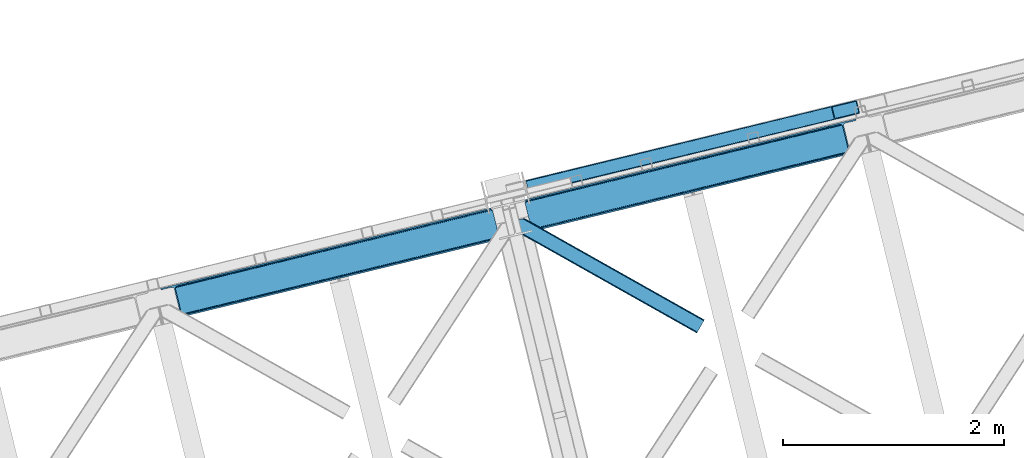
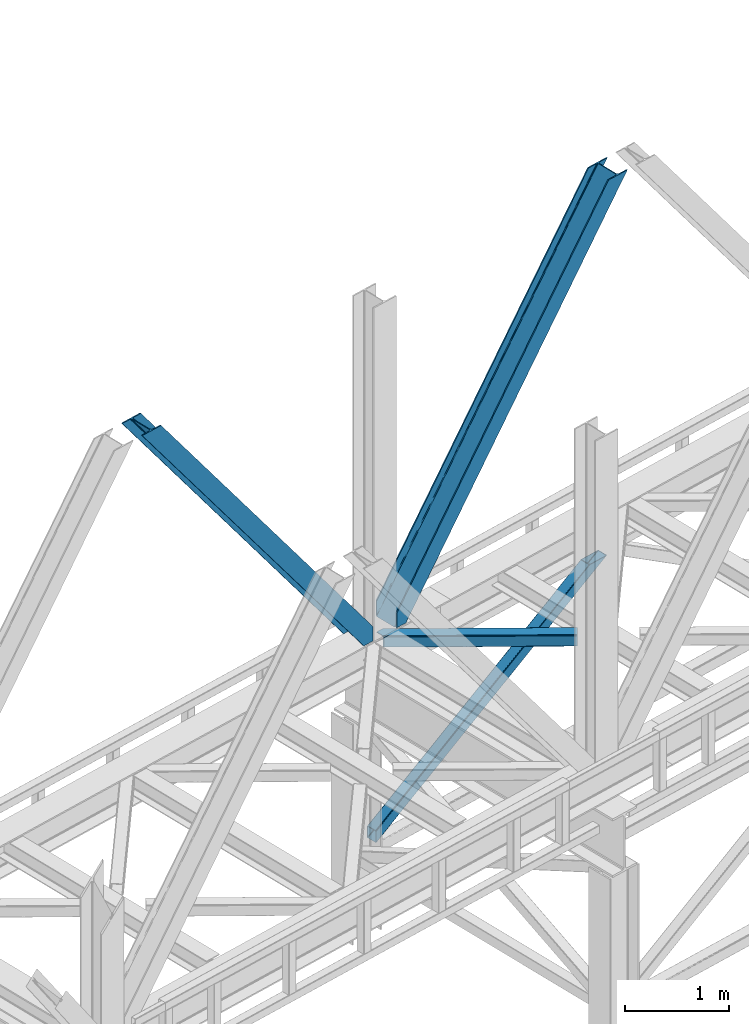
# One storey, part 45 of 93: 4 members.
"""IFC4 building model written with IfcOpenShell, lengths in millimetres."""

from ifc_helpers import new_model, entity, si_unit, converted_unit, derived_unit, direction, frame, origin, place, context, subcontext, project, spatial, triangles, type_object, element, save


model = new_model("IFC4")

# Units and contexts
model_context = context("Model", 3, precision=0.01, world=origin(), true_north=direction((6.12303176911189e-17, 1.0)))
plan_context = context("Plan", 3, precision=0.01, world=origin(), true_north=direction((6.12303176911189e-17, 1.0)))
body_context = subcontext(model_context, "Body", "Model", "MODEL_VIEW")
ifc_project = project(units=[si_unit("LENGTHUNIT", "METRE", prefix="MILLI"), si_unit("AREAUNIT", "SQUARE_METRE"), si_unit("VOLUMEUNIT", "CUBIC_METRE"), converted_unit("PLANEANGLEUNIT", "DEGREE", entity("IfcRatioMeasure", 0.0174532925199433), si_unit("PLANEANGLEUNIT", "RADIAN"), dimensions=[0, 0, 0, 0, 0, 0, 0]), si_unit("MASSUNIT", "GRAM", prefix="KILO"), derived_unit("MASSDENSITYUNIT", [(si_unit("MASSUNIT", "GRAM", prefix="KILO"), 1), (si_unit("LENGTHUNIT", "METRE"), -3)]), derived_unit("MOMENTOFINERTIAUNIT", [(si_unit("LENGTHUNIT", "METRE"), 4)]), si_unit("TIMEUNIT", "SECOND"), si_unit("FREQUENCYUNIT", "HERTZ"), si_unit("THERMODYNAMICTEMPERATUREUNIT", "DEGREE_CELSIUS"), derived_unit("THERMALTRANSMITTANCEUNIT", [(si_unit("MASSUNIT", "GRAM", prefix="KILO"), 1), (si_unit("THERMODYNAMICTEMPERATUREUNIT", "KELVIN"), -1), (si_unit("TIMEUNIT", "SECOND"), -3)]), derived_unit("VOLUMETRICFLOWRATEUNIT", [(si_unit("LENGTHUNIT", "METRE"), 3), (si_unit("TIMEUNIT", "SECOND"), -1)]), derived_unit("MASSFLOWRATEUNIT", [(si_unit("MASSUNIT", "GRAM", prefix="KILO"), 1), (si_unit("TIMEUNIT", "SECOND"), -1)]), derived_unit("ROTATIONALFREQUENCYUNIT", [(si_unit("TIMEUNIT", "SECOND"), -1)]), si_unit("ELECTRICCURRENTUNIT", "AMPERE"), si_unit("ELECTRICVOLTAGEUNIT", "VOLT"), si_unit("POWERUNIT", "WATT"), si_unit("FORCEUNIT", "NEWTON", prefix="KILO"), si_unit("ILLUMINANCEUNIT", "LUX"), si_unit("LUMINOUSFLUXUNIT", "LUMEN"), si_unit("LUMINOUSINTENSITYUNIT", "CANDELA"), derived_unit("USERDEFINED", [(si_unit("MASSUNIT", "GRAM", prefix="KILO"), -1), (si_unit("LENGTHUNIT", "METRE"), -2), (si_unit("TIMEUNIT", "SECOND"), 3), (si_unit("LUMINOUSFLUXUNIT", "LUMEN"), 1)]), derived_unit("LINEARVELOCITYUNIT", [(si_unit("LENGTHUNIT", "METRE"), 1), (si_unit("TIMEUNIT", "SECOND"), -1)]), si_unit("PRESSUREUNIT", "PASCAL"), derived_unit("USERDEFINED", [(si_unit("LENGTHUNIT", "METRE"), -2), (si_unit("MASSUNIT", "GRAM", prefix="KILO"), 1), (si_unit("TIMEUNIT", "SECOND"), -2)]), derived_unit("LINEARFORCEUNIT", [(si_unit("MASSUNIT", "GRAM", prefix="KILO"), 1), (si_unit("LENGTHUNIT", "METRE"), 1), (si_unit("TIMEUNIT", "SECOND"), -2), (si_unit("LENGTHUNIT", "METRE"), -1)]), derived_unit("PLANARFORCEUNIT", [(si_unit("MASSUNIT", "GRAM", prefix="KILO"), 1), (si_unit("LENGTHUNIT", "METRE"), 1), (si_unit("TIMEUNIT", "SECOND"), -2), (si_unit("LENGTHUNIT", "METRE"), -2)])], contexts=[model_context, plan_context])

# Site, building, storey
site_placement = place(None, origin())
site = spatial("IfcSite", under=ifc_project, at=site_placement, CompositionType="ELEMENT")
building_placement = place(site_placement, origin())
building = spatial("IfcBuilding", under=site, at=building_placement, CompositionType="ELEMENT")
storey_placement = place(building_placement, frame((0.0, 0.0, 15900.0)))
storey = spatial("IfcBuildingStorey", under=building, at=storey_placement, CompositionType="ELEMENT", Elevation=15900.0)

# Members
member_type_1 = type_object("IfcMemberType", PredefinedType="BRACE")
member_1_placement = place(storey_placement, frame((-46122.2870727539, 9414.76370544434, 3694.99929199219)))
element("IfcMember", 1, at=member_1_placement, inside=storey, type_object=member_type_1, ObjectType="Steel Vertical Brace", PredefinedType="BRACE", context=body_context, shape_type="Tessellation", body=[
    triangles([(3067.37091064453, 755.49225769043, 0.827856445310317), (3068.02668457031, 754.50743408203, 1.13248901367115), (3066.59886474609, 754.045834350585, 0.0), (3064.67805175781, 761.925585937499, 0.0), (3064.21761474609, 752.73196105957, 7.29955444335792), (3064.21761474609, 752.73196105957, 0.0), (3059.99926757813, 741.228012084961, 0.0), (3059.6876586914, 743.591821289063, 30.563250732419), (3059.80393066406, 742.210510253906, 42.2602111816377), (3059.81788330078, 745.527749633789, 0.0), (3059.81788330078, 745.527749633789, 24.1799194335908), (3059.80393066406, 742.210510253906, 171.115136718749), (3059.99926757813, 741.228012084961, 171.175598144531), (3061.29686279297, 749.56936340332, 14.6921264648408), (3061.29686279297, 749.56936340332, 0.0), (3060.72015380859, 747.995040893555, 18.3872497558586), (215.726367187497, 48.9359664916992, 3911.00081176758), (310.450817871089, 72.0264175415032, 3911.00081176758), (192.834741210936, 54.7931671142578, 3911.00081176758), (198.969250488277, 50.2783264160153, 3911.00081176758), (207.010620117188, 48.2214752197269, 3911.00081176758), (189.532617187499, 61.0782485961918, 3911.00081176758), (3062.84095458984, 729.569421386719, 171.175598144531), (313.529699707025, 59.396374511718, 3911.00081176758), (3062.84095458984, 729.569421386719, 0.0), (2945.0109375, 700.846755981445, 0.0), (69.865502929686, 0.0, 3911.00081176758), (2941.93205566406, 713.477380371094, 0.0), (66.78662109375, 12.6300430297852, 3911.00081176758), (161.511071777342, 35.7204940795891, 3911.00081176758), (3036.65650634765, 736.567831420898, 0.0), (3054.3251953125, 759.401321411133, 0.0), (3054.28333740234, 752.301754760741, 0.0), (179.179760742183, 58.5539840698239, 3911.00081176758), (179.13790283203, 51.4544174194325, 3911.00081176758), (3050.91610107422, 745.469613647461, 0.0), (175.7706665039, 44.622857666016, 3911.00081176758), (3044.72578125, 739.944369506835, 0.0), (169.580346679686, 39.0970321655277, 3911.00081176758), (2999.14251708984, 985.772387695311, 0.0), (123.997082519527, 284.925631713866, 3911.00081176758), (2972.94876708984, 997.914669799804, 0.0), (2981.66916503906, 998.62974243164, 0.0), (106.523730468747, 297.782405090331, 3911.00081176758), (97.8033325195283, 297.067913818359, 3911.00081176758), (2989.70588378906, 996.572891235352, 0.0), (114.560449218749, 295.725553894043, 3911.00081176758), (2995.84039306641, 992.058050537109, 0.0), (120.694958496089, 291.211294555664, 3911.00081176758), (3.07888183593604, 273.977462768555, 3911.00081176758), (2878.22431640625, 974.82421875, 0.0), (2875.14543457031, 987.454843139649, 0.0), (0.0, 286.60750579834, 3911.00081176758), (3009.50002441406, 988.296652221679, 0.0), (134.354589843744, 287.449896240234, 3911.00081176758), (143.954003906249, 306.906266784668, 3911.00081176758), (243.668847656249, 346.004461669922, 3911.00081176758), (152.018627929683, 310.283386230469, 3911.00081176758), (137.763684082027, 301.381604003906, 3911.00081176758), (134.391796874996, 294.549462890625, 3911.00081176758), (246.747729492185, 333.373837280273, 3911.00081176758), (2992.97545166015, 1016.17750854492, 171.175598144531), (2992.97545166015, 1016.17750854492, 0.0), (2995.81713867188, 1004.51891784668, 171.175598144531), (2996.10084228515, 1003.55734863281, 171.115136718749), (2996.10084228515, 1003.55734863281, 42.2602111816377), (2995.81713867188, 1004.51891784668, 0.0), (3004.85844726562, 996.247329711914, 0.0), (2997.63563232421, 1000.61683044434, 0.0), (3000.81218261718, 997.712356567383, 0.0), (3007.57921142578, 996.176403808593, 0.0), (2996.63104248047, 1002.27719421387, 30.563250732419), (2997.79841308593, 1000.74124145508, 25.1542785644524), (2999.21228027344, 998.890191650391, 18.6337463378877), (3000.81218261718, 997.712356567383, 14.6921264648408), (3004.85844726562, 996.247329711914, 7.29955444335792), (3009.05819091797, 996.424063110351, 1.13248901367115), (3008.92796630859, 995.248553466796, 0.827856445310317)], [[1, 2, 3], [3, 4, 1], [5, 6, 3], [7, 8, 9], [7, 10, 11], [11, 8, 7], [9, 12, 13], [13, 7, 9], [14, 10, 15], [10, 14, 16], [11, 10, 16], [6, 5, 15], [14, 15, 5], [3, 2, 5], [17, 18, 12], [12, 9, 17], [1, 19, 5], [19, 20, 16], [16, 14, 19], [14, 5, 19], [20, 21, 8], [8, 11, 20], [9, 8, 21], [21, 17, 9], [11, 16, 20], [5, 2, 1], [1, 4, 19], [22, 19, 4], [13, 12, 18], [23, 13, 24], [18, 24, 13], [23, 25, 7], [7, 13, 23], [24, 26, 23], [24, 27, 26], [26, 25, 23], [28, 26, 29], [27, 29, 26], [29, 30, 28], [31, 28, 30], [32, 33, 34], [35, 34, 33], [33, 36, 35], [37, 35, 36], [36, 38, 37], [39, 37, 38], [38, 31, 39], [30, 39, 31], [40, 32, 41], [34, 41, 32], [42, 43, 44], [44, 45, 42], [43, 46, 47], [47, 44, 43], [46, 48, 49], [49, 47, 46], [48, 40, 41], [41, 49, 48], [45, 50, 51], [51, 42, 45], [52, 51, 50], [50, 53, 52], [4, 54, 55], [55, 22, 4], [41, 34, 55], [37, 39, 21], [30, 27, 24], [29, 27, 30], [39, 30, 17], [34, 35, 19], [35, 37, 20], [47, 56, 44], [53, 45, 57], [45, 44, 58], [53, 50, 45], [47, 49, 59], [49, 41, 60], [55, 34, 22], [17, 21, 39], [19, 35, 20], [21, 20, 37], [19, 22, 34], [24, 17, 30], [24, 18, 17], [58, 44, 56], [59, 49, 60], [55, 60, 41], [59, 56, 47], [58, 57, 45], [57, 58, 61], [57, 52, 53], [52, 57, 62], [63, 52, 62], [64, 62, 57], [65, 64, 61], [57, 61, 64], [61, 58, 65], [66, 65, 58], [64, 67, 62], [63, 62, 67], [32, 40, 54], [46, 43, 67], [42, 52, 63], [51, 52, 42], [43, 42, 63], [40, 48, 68], [48, 46, 69], [36, 7, 38], [26, 31, 25], [31, 38, 25], [26, 28, 31], [36, 33, 10], [33, 32, 6], [10, 7, 36], [54, 40, 68], [67, 69, 46], [63, 67, 43], [48, 69, 70], [70, 68, 48], [71, 54, 68], [32, 54, 4], [10, 33, 15], [33, 6, 15], [7, 25, 38], [32, 4, 6], [3, 6, 4], [67, 72, 73], [65, 66, 64], [67, 64, 66], [66, 72, 67], [69, 74, 75], [69, 73, 74], [76, 77, 71], [71, 68, 76], [76, 68, 70], [70, 75, 76], [75, 70, 69], [73, 69, 67], [60, 78, 76], [76, 59, 60], [76, 75, 59], [75, 74, 59], [78, 77, 76], [54, 78, 60], [60, 55, 54], [73, 59, 74], [59, 73, 72], [56, 59, 72], [72, 66, 56], [58, 56, 66], [77, 78, 71], [54, 71, 78]]),
])
member_type_2 = type_object("IfcMemberType", PredefinedType="BRACE")
member_2_placement = place(storey_placement, frame((-42823.6093505859, 10220.1157104492, 3694.99929199219)))
element("IfcMember", 2, at=member_2_placement, inside=storey, type_object=member_type_2, ObjectType="Steel Vertical Brace", PredefinedType="BRACE", context=body_context, shape_type="Tessellation", body=[
    triangles([(58.5313110351563, 27.8808563232415, 0.0), (60.452124023439, 20.0011047363278, 0.0), (59.0987182617173, 20.928955078125, 0.827856445310317), (58.97314453125, 19.7534454345696, 1.13248901367115), (72.2095458984404, 11.6585906982418, 0.0), (71.4002929687485, 13.9003143310547, 30.563250732419), (70.228271484375, 15.4362670898427, 25.1542785644524), (72.2095458984404, 11.6585906982418, 171.175598144531), (71.9304931640654, 12.6201599121086, 42.2602111816377), (71.9304931640654, 12.6201599121086, 171.115136718749), (70.3957031250029, 15.5606781005863, 0.0), (68.8190551757798, 17.2873168945316, 18.6337463378877), (67.2191528320327, 18.4663146972653, 14.6921264648408), (63.168237304686, 19.9301788330067, 7.29955444335792), (63.168237304686, 19.9301788330067, 0.0), (67.2191528320327, 18.4663146972653, 0.0), (2821.28360595703, 682.803671264648, 3911.00081176758), (2916.00805664063, 705.894122314452, 3911.00081176758), (2933.63488769531, 721.628045654297, 3911.00081176758), (2930.26765136719, 714.795904541015, 3911.00081176758), (2933.67674560547, 728.727612304687, 3911.00081176758), (2924.07733154297, 709.270660400391, 3911.00081176758), (2824.36248779297, 670.173046874999, 3911.00081176758), (75.0512329101548, 0.0, 171.175598144531), (75.0512329101548, 0.0, 0.0), (192.881249999999, 28.7226654052738, 0.0), (3068.03133544922, 729.570584106445, 3911.00081176758), (3064.95245361328, 742.200045776366, 3911.00081176758), (189.802368164063, 41.3532897949208, 0.0), (2970.22335205078, 719.109594726562, 3911.00081176758), (95.0779174804702, 18.2628387451168, 0.0), (2961.50760498047, 718.395684814453, 3911.00081176758), (86.3621704101533, 17.5477661132809, 0.0), (2953.47088623047, 720.451373291015, 3911.00081176758), (78.32080078125, 19.6046173095692, 0.0), (2947.33172607422, 724.966213989257, 3911.00081176758), (72.1862915039092, 24.1194580078118, 0.0), (2944.02960205078, 731.251876831055, 3911.00081176758), (68.8841674804717, 30.4039581298821, 0.0), (2888.85157470703, 957.624105834961, 3911.00081176758), (13.7061401367173, 256.776187133788, 0.0), (2888.88878173828, 964.722509765625, 3911.00081176758), (13.7433471679688, 263.875753784179, 0.0), (2892.26066894531, 971.554650878907, 3911.00081176758), (17.115234375, 270.707894897461, 0.0), (2898.45098876953, 977.079895019531, 3911.00081176758), (23.3055541992217, 276.233139038086, 0.0), (2906.52026367188, 980.457595825195, 3911.00081176758), (31.3748291015654, 279.609677124023, 0.0), (3001.24471435547, 1003.548046875, 3911.00081176758), (126.099279785158, 302.700128173828, 0.0), (2998.16583251953, 1016.17750854492, 3911.00081176758), (123.020397949222, 315.330752563475, 0.0), (2878.49406738281, 955.098678588867, 3911.00081176758), (3.3486328125, 254.251922607422, 0.0), (2869.05743408203, 965.899182128906, 3911.00081176758), (2861.02071533203, 967.956033325196, 3911.00081176758), (2754.49698486328, 956.781134033203, 3911.00081176758), (2852.30496826172, 967.242123413085, 3911.00081176758), (2757.57586669922, 944.150509643554, 3911.00081176758), (2875.19194335937, 961.384341430663, 3911.00081176758), (5.19038085937791, 286.608087158203, 171.175598144531), (5.19038085937791, 286.608087158203, 0.0), (8.03206787109229, 274.94949645996, 171.175598144531), (8.22275390625146, 273.966998291015, 171.115136718749), (8.22275390625146, 273.966998291015, 42.2602111816377), (8.03206787109229, 274.94949645996, 0.0), (3.80906982421584, 263.445547485351, 0.0), (6.72982177734229, 266.608145141601, 0.0), (8.21345214844041, 270.649758911133, 0.0), (1.42781982421729, 262.130511474608, 0.0), (3.80906982421584, 263.445547485351, 7.29955444335792), (8.34367675780959, 272.58568725586, 30.563250732419), (8.21345214844041, 270.649758911133, 24.1799194335908), (7.30653076172166, 268.182467651366, 18.3872497558586), (6.72982177734229, 266.608145141601, 14.6921264648408), (0.0, 261.670074462891, 1.13248901367115), (0.65577392578416, 260.685250854493, 0.827856445310317)], [[1, 2, 3], [4, 3, 2], [5, 6, 7], [5, 8, 9], [10, 9, 8], [9, 6, 5], [11, 12, 13], [11, 7, 12], [14, 4, 2], [2, 15, 14], [16, 13, 14], [14, 15, 16], [13, 16, 11], [7, 11, 5], [17, 18, 10], [9, 10, 18], [19, 3, 14], [14, 20, 19], [14, 13, 20], [13, 12, 20], [3, 4, 14], [19, 21, 1], [1, 3, 19], [6, 20, 7], [6, 22, 20], [12, 7, 20], [18, 22, 9], [6, 9, 22], [8, 17, 10], [23, 8, 24], [8, 23, 17], [25, 24, 5], [8, 5, 24], [23, 26, 27], [26, 23, 24], [25, 26, 24], [28, 27, 26], [26, 29, 28], [30, 28, 29], [29, 31, 30], [32, 30, 31], [31, 33, 32], [34, 32, 33], [33, 35, 34], [36, 34, 35], [35, 37, 36], [38, 36, 37], [37, 39, 38], [40, 38, 39], [39, 41, 40], [42, 40, 43], [41, 43, 40], [44, 42, 45], [43, 45, 42], [46, 44, 47], [45, 47, 44], [48, 46, 49], [47, 49, 46], [50, 48, 51], [49, 51, 48], [52, 50, 53], [51, 53, 50], [21, 54, 55], [55, 1, 21], [54, 21, 40], [20, 22, 32], [18, 23, 27], [17, 23, 18], [22, 18, 30], [21, 19, 36], [19, 20, 34], [56, 46, 57], [58, 59, 52], [59, 57, 48], [58, 60, 59], [56, 61, 44], [61, 54, 42], [40, 21, 38], [30, 32, 22], [36, 19, 34], [32, 34, 20], [36, 38, 21], [27, 30, 18], [27, 28, 30], [48, 57, 46], [44, 61, 42], [40, 42, 54], [44, 46, 56], [48, 52, 59], [52, 48, 50], [58, 53, 62], [58, 52, 53], [53, 63, 62], [64, 58, 62], [60, 64, 65], [64, 60, 58], [59, 60, 65], [65, 66, 59], [67, 64, 62], [62, 63, 67], [11, 35, 5], [68, 41, 55], [69, 70, 43], [69, 43, 68], [55, 71, 68], [67, 63, 47], [67, 45, 70], [55, 39, 1], [37, 16, 15], [2, 1, 15], [15, 1, 39], [11, 16, 37], [25, 5, 33], [39, 55, 41], [49, 47, 63], [43, 70, 45], [47, 45, 67], [43, 41, 68], [53, 49, 63], [53, 51, 49], [31, 25, 33], [35, 11, 37], [39, 37, 15], [35, 33, 5], [31, 26, 25], [26, 31, 29], [72, 68, 71], [67, 73, 66], [67, 70, 74], [74, 73, 67], [64, 67, 66], [66, 65, 64], [75, 70, 76], [75, 74, 70], [69, 76, 70], [76, 69, 72], [68, 72, 69], [71, 77, 72], [78, 61, 72], [61, 56, 75], [75, 76, 61], [76, 72, 61], [56, 57, 73], [73, 74, 56], [57, 59, 66], [66, 73, 57], [74, 75, 56], [72, 77, 78], [54, 61, 55], [78, 55, 61], [71, 55, 78], [78, 77, 71]]),
])
member_type_3 = type_object("IfcMemberType", PredefinedType="BRACE")
member_3_placement = place(storey_placement, frame((-42813.6425170898, 10559.9356658936, 965.735650634766)))
element("IfcMember", 3, at=member_3_placement, inside=storey, type_object=member_type_3, ObjectType="Steel Vertical Brace", PredefinedType="BRACE", context=body_context, shape_type="Tessellation", body=[
    triangles([(2998.54720458984, 840.489395141602, 1902.27225952148), (3024.23865966796, 734.56097717285, 1902.27225952148), (42.5415893554673, 11.3690734863267, 4.45903015136719), (16.6268920898438, 117.244006347655, 4.31717834472511), (0.176733398438955, 120.724026489257, 0.782510375975107), (0.0, 121.443749999999, 4.34159545898365), (2981.88310546875, 844.679837036132, 1902.27225952148), (2987.68275146484, 845.460021972656, 1902.27225952148), (2992.88243408203, 844.937960815429, 1902.27225952148), (7.26932373047021, 120.796115112304, 1.96615905761428), (2996.70080566406, 843.192718505859, 1902.27225952148), (13.8177612304644, 119.712460327148, 3.70442504882521), (0.213940429683134, 120.565896606444, 0.0), (3016.85771484375, 725.1650390625, 1902.27225952148), (29.4307617187515, 0.711584472655886, 0.868551635740005), (35.8768798828096, 3.93231811523401, 2.12312622070021), (29.3935546875, 0.86041259765625, 0.127899169921875), (3011.34642333984, 723.202368164062, 1902.27225952148), (29.6028442382813, 0.0, 4.43112487792678), (3021.24349365234, 728.013702392578, 1902.27225952148), (3023.83868408203, 731.313500976561, 1902.27225952148), (41.1881835937456, 7.89021606445203, 3.8532531738274), (0.0, 121.443749999999, 132.509353637695), (2780.51865234375, 795.839794921874, 1902.27225952148), (0.279052734375, 120.305447387695, 135.835894775388), (2775.00270996094, 793.875961303711, 1902.27225952148), (0.55810546875, 119.167144775391, 139.162435913084), (2770.61693115234, 791.028460693358, 1902.27225952148), (1.22783203124709, 116.419638061523, 140.541421508788), (2768.02639160156, 787.728662109374, 1902.27225952148), (1.89755859375146, 113.670968627928, 141.921569824219), (2767.62176513672, 784.481185913086, 1902.27225952148), (2793.31787109375, 678.552767944335, 1902.27225952148), (27.709936523439, 7.77161865234302, 141.999472045896), (28.379663085936, 5.02411193847547, 140.622811889647), (2795.16427001953, 675.849444580077, 1902.27225952148), (29.0493896484331, 2.27544250488245, 139.247314453125), (2798.97799072265, 674.104202270508, 1902.27225952148), (29.3284423828081, 1.13713989257667, 135.92309875488), (2804.18232421875, 673.58214111328, 1902.27225952148), (29.6028442382813, 0.0, 132.597720336911), (2809.98197021485, 674.362326049804, 1902.27225952148), (3.90208740234084, 110.042120361328, 0.32207336425563), (27.914575195311, 11.9376434326168, 0.453460693359375), (27.3099609374985, 9.42151794433448, 0.118597412107192), (2.32078857421584, 111.925726318359, 0.00930175781104481), (3015.90893554688, 736.656198120116, 1902.27225952148), (2992.10108642578, 834.810671997069, 1902.27225952148), (1.6278076171875, 114.77322692871, 3.08236999511428), (2986.44096679687, 839.258074951171, 1902.27225952148), (2981.23663330078, 839.780136108398, 1902.27225952148), (2.17196044921729, 112.538479614257, 0.67088928222438), (2990.2546875, 837.512832641602, 1902.27225952148), (1.09295654296875, 116.966116333007, 5.44850463866896), (2975.43698730469, 839.001113891602, 1902.27225952148), (0.94877929687209, 117.557940673827, 9.04828491210719), (28.379663085936, 5.02411193847547, 5.80429687499782), (28.658715820311, 3.88580932617151, 9.13083801269386), (3003.01669921875, 725.297589111327, 1902.27225952148), (28.100610351561, 6.16241455078125, 2.47775573730178), (3008.52799072266, 727.261422729491, 1902.27225952148), (27.4680908203081, 8.76109313964844, 0.596475219725107), (3012.91376953125, 730.108923339843, 1902.27225952148), (3015.50430908203, 733.408721923828, 1902.27225952148), (0.94877929687209, 117.557940673827, 127.808477783201), (2788.84837646484, 793.744573974609, 1902.27225952148), (2.17196044921729, 112.532666015624, 135.841708374021), (2776.36076660156, 785.633441162108, 1902.27225952148), (2775.95614013672, 782.385964965819, 1902.27225952148), (1.50223388672021, 115.281335449217, 134.461560058593), (2778.95130615234, 788.933239746093, 1902.27225952148), (1.22783203124709, 116.419638061523, 131.135018920897), (2783.33708496093, 791.780740356444, 1902.27225952148), (2.84168701171438, 109.785159301757, 137.220693969724), (2805.42410888672, 679.784088134766, 1902.27225952148), (2801.6103881836, 681.529330444335, 1902.27225952148), (2816.4280883789, 680.041049194335, 1902.27225952148), (2810.62844238281, 679.262026977538, 1902.27225952148), (2799.75933837891, 684.231491088867, 1902.27225952148), (28.379663085936, 5.02411193847547, 131.216409301756), (28.100610351561, 6.16241455078125, 134.541787719725), (27.430883789064, 8.90992126464698, 135.917285156247), (26.7611572265596, 11.6574279785145, 137.292782592773), (28.658715820311, 3.88580932617151, 127.891030883788)], [[1, 2, 3], [3, 4, 1], [5, 6, 7], [8, 9, 10], [10, 5, 8], [11, 1, 4], [4, 12, 11], [9, 11, 12], [12, 10, 9], [10, 13, 5], [7, 8, 5], [14, 15, 16], [15, 17, 16], [15, 14, 18], [18, 19, 15], [16, 20, 14], [21, 20, 22], [16, 22, 20], [2, 21, 3], [22, 3, 21], [6, 23, 24], [24, 7, 6], [23, 25, 26], [25, 27, 28], [27, 29, 30], [29, 31, 32], [32, 30, 29], [30, 28, 27], [28, 26, 25], [26, 24, 23], [33, 32, 34], [31, 34, 32], [35, 36, 33], [37, 38, 36], [39, 40, 38], [41, 42, 40], [40, 39, 41], [38, 37, 39], [36, 35, 37], [33, 34, 35], [41, 19, 42], [18, 42, 19], [43, 10, 12], [44, 3, 22], [44, 22, 16], [3, 44, 4], [12, 4, 43], [43, 4, 44], [16, 45, 44], [16, 17, 45], [10, 46, 13], [46, 10, 43], [47, 48, 44], [43, 44, 48], [49, 50, 51], [52, 53, 50], [53, 46, 43], [53, 52, 46], [43, 48, 53], [50, 49, 52], [51, 54, 49], [51, 55, 54], [56, 54, 55], [57, 58, 59], [60, 57, 61], [62, 60, 63], [64, 47, 44], [44, 45, 64], [45, 62, 64], [63, 64, 62], [61, 63, 60], [59, 61, 57], [65, 56, 66], [55, 66, 56], [67, 68, 69], [70, 71, 68], [72, 73, 71], [65, 66, 73], [73, 72, 65], [71, 70, 72], [68, 67, 70], [69, 74, 67], [53, 9, 8], [48, 47, 1], [11, 53, 1], [53, 11, 9], [53, 48, 1], [50, 53, 8], [55, 7, 24], [7, 50, 8], [51, 7, 55], [51, 50, 7], [20, 64, 14], [47, 2, 1], [2, 64, 21], [64, 2, 47], [20, 21, 64], [18, 59, 42], [14, 64, 63], [63, 61, 18], [61, 59, 18], [18, 14, 63], [71, 26, 68], [24, 66, 55], [24, 73, 66], [71, 24, 26], [71, 73, 24], [69, 32, 33], [68, 26, 28], [30, 68, 28], [68, 30, 32], [69, 68, 32], [40, 75, 76], [42, 59, 77], [77, 78, 42], [78, 75, 42], [40, 42, 75], [38, 40, 76], [33, 79, 69], [76, 33, 36], [33, 76, 79], [36, 38, 76], [41, 39, 80], [81, 35, 82], [37, 81, 39], [81, 37, 35], [80, 39, 81], [83, 31, 74], [82, 35, 34], [34, 83, 82], [34, 31, 83], [80, 84, 41], [19, 60, 17], [19, 41, 84], [84, 58, 19], [19, 58, 57], [60, 19, 57], [60, 62, 17], [23, 65, 72], [70, 25, 72], [31, 29, 67], [31, 67, 74], [67, 29, 70], [25, 23, 72], [70, 29, 27], [70, 27, 25], [23, 56, 65], [49, 13, 46], [49, 54, 5], [5, 13, 49], [54, 56, 6], [23, 6, 56], [54, 6, 5], [69, 79, 83], [83, 74, 69], [84, 80, 78], [80, 81, 75], [81, 82, 76], [82, 83, 79], [79, 76, 82], [76, 75, 81], [75, 78, 80], [78, 77, 84], [58, 84, 77], [77, 59, 58]]),
])
member_type_4 = type_object("IfcMemberType", PredefinedType="BRACE")
member_4_placement = place(storey_placement, frame((-42920.6313354492, 9296.59940643311, 3511.0000579834)))
element("IfcMember", 4, at=member_4_placement, inside=storey, type_object=member_type_4, ObjectType="Steel Horizontal Brace", PredefinedType="BRACE", context=body_context, shape_type="Tessellation", body=[
    triangles([(1656.08961181641, 0.0, 122.500662231447), (1656.74073486328, 1.16039428710974, 129.197927856447), (23.8869140625029, 919.172383117675, 122.500662231447), (23.4543823242202, 920.945530700683, 129.197927856447), (1658.60573730469, 4.46600646972547, 134.874325561526), (22.2265502929731, 925.991734313964, 134.874325561526), (1661.38696289063, 9.41279754638708, 138.667117309571), (20.3848022460952, 933.543598937988, 138.667117309571), (1664.67513427735, 15.2484878540035, 139.999594116212), (18.2128417968779, 942.452357482909, 139.999594116212), (1656.08961181641, 0.0, 17.5000946044929), (23.8869140625029, 919.172383117675, 17.5000946044929), (1716.19757080078, 106.738252258301, 139.999594116212), (69.4422729492217, 1034.10722808838, 139.999594116212), (0.0, 1017.17919158936, 139.999594116212), (1719.48574218751, 112.573361206054, 138.667117309571), (78.9672729492231, 1036.42917938232, 138.667117309571), (1722.27161865235, 117.520733642577, 134.874325561526), (87.0458496093779, 1038.39766387939, 134.874325561526), (1724.13197021485, 120.825764465331, 129.197927856447), (92.4408691406279, 1039.71269989014, 129.197927856447), (1724.78309326172, 121.986158752441, 122.500662231447), (94.3337768554702, 1040.17429962158, 122.500662231447), (1724.78309326172, 121.986158752441, 17.5000946044929), (94.3337768554702, 1040.17429962158, 17.5000946044929), (1656.74073486328, 1.16039428710974, 10.8028289794929), (1658.60573730469, 4.46600646972547, 5.12526855468968), (196.053149414067, 824.821165466308, 8.8831787109375), (196.071752929689, 825.066499328614, 8.50064392089917), (23.3660156250044, 921.307136535645, 10.8691040039084), (195.062512207034, 824.999061584473, 9.50058288574292), (195.732238769531, 824.879301452636, 9.08316650390771), (23.2590454101592, 921.747807312011, 9.50058288574292), (195.220642089844, 828.569773864745, 5.12526855468968), (1664.67513427735, 15.2484878540035, 0.0), (1661.38696289063, 9.41279754638708, 1.33247680664135), (193.378894042973, 836.122801208496, 1.33247680664135), (191.206933593756, 845.031559753417, 0.0), (1716.19757080078, 106.738252258301, 0.0), (157.157849121097, 984.711405944823, 0.0), (191.346459960943, 843.223530578613, 9.20757751465135), (191.290649414063, 844.068827819823, 8.85411071777344), (191.104614257813, 845.46060333252, 8.41343994140698), (18.8686157226621, 939.77345123291, 9.50058288574292), (1724.13197021485, 120.825764465331, 10.8028289794929), (92.0548461914077, 1039.61851959228, 10.8702667236357), (150.916369628911, 1006.08800811767, 9.50058288574292), (1722.27161865235, 117.520733642577, 5.12526855468968), (153.144140625001, 1001.17202911377, 5.12526855468968), (152.293029785156, 1004.67646636963, 8.50064392089917), (151.604699707037, 1005.38223724365, 9.00061340332104), (91.5804565429717, 1039.50341033936, 9.50058288574292), (1719.48574218751, 112.573361206054, 1.33247680664135), (154.985888671879, 993.620164489746, 1.33247680664135), (156.246276855469, 986.7019821167, 9.11688537597729), (155.809094238284, 987.634483337402, 9.42384338378906), (156.692761230472, 985.761341857909, 8.80760192871094), (157.129943847656, 984.828840637207, 8.50064392089917), (155.311450195317, 988.062364196778, 9.50058288574292), (72.3072143554746, 1034.80602264404, 9.50058288574292), (159.427478027348, 975.399183654785, 6.99957275390625), (188.937304687504, 854.343782043457, 6.99957275390625), (1668.11213378907, 21.3475341796875, 6.99957275390625), (1712.76522216797, 100.639205932617, 6.99957275390625), (19.9569213867217, 935.302793884277, 12.1260040283232), (1662.0380859375, 10.5656341552731, 12.1260040283232), (1664.82396240235, 15.5124252319329, 8.3320495605476), (1659.52196044922, 6.09904632568396, 24.4996673583992), (1660.177734375, 7.26002197265552, 17.8035644531265), (21.6172851562515, 928.484605407715, 24.4996673583992), (21.1847534179688, 930.256590270996, 17.8035644531265), (1716.04874267578, 106.47431488037, 8.3320495605476), (1718.83461914063, 111.421105957032, 12.1260040283232), (77.0883178710938, 1035.97106781006, 12.1260040283232), (1720.69497070313, 114.726718139647, 17.8035644531265), (82.4833374023438, 1037.2861038208, 17.8035644531265), (1721.35074462891, 115.887112426757, 24.4996673583992), (84.3808959960952, 1037.74770355225, 24.4996673583992), (1659.52196044922, 6.09904632568396, 115.501089477541), (21.6172851562515, 928.484605407715, 115.501089477541), (21.1847534179688, 930.256590270996, 122.196029663086), (19.9569213867217, 935.302793884277, 127.87475280762), (15.9432128906265, 951.764579772949, 133.000021362306), (18.1151733398438, 942.855821228028, 131.667544555665), (0.0, 1017.17919158936, 133.000021362306), (1668.11213378907, 21.3475341796875, 133.000021362306), (1664.82396240235, 15.5124252319329, 131.667544555665), (1662.0380859375, 10.5656341552731, 127.87475280762), (1660.177734375, 7.26002197265552, 122.196029663086), (1718.83461914063, 111.421105957032, 127.87475280762), (1720.69497070313, 114.726718139647, 122.196029663086), (1721.35074462891, 115.887112426757, 115.501089477541), (1712.76522216797, 100.639205932617, 133.000021362306), (1716.04874267578, 106.47431488037, 131.667544555665), (77.0883178710938, 1035.97106781006, 127.87475280762), (69.0143920898481, 1034.00258331299, 131.667544555665), (82.4833374023438, 1037.2861038208, 122.196029663086), (59.4893920898467, 1031.68063201904, 133.000021362306), (84.3808959960952, 1037.74770355225, 115.501089477541)], [[1, 2, 3], [4, 3, 2], [2, 5, 4], [6, 4, 5], [5, 7, 6], [8, 6, 7], [7, 9, 8], [10, 8, 9], [11, 1, 12], [3, 12, 1], [13, 10, 9], [10, 13, 14], [15, 10, 14], [13, 16, 17], [17, 14, 13], [16, 18, 19], [19, 17, 16], [18, 20, 21], [21, 19, 18], [20, 22, 23], [23, 21, 20], [22, 24, 23], [25, 23, 24], [26, 11, 12], [27, 28, 29], [26, 30, 31], [31, 27, 26], [31, 32, 27], [30, 33, 31], [29, 34, 27], [35, 36, 37], [37, 38, 35], [36, 27, 34], [34, 37, 36], [12, 30, 26], [39, 35, 38], [38, 40, 39], [41, 42, 29], [42, 43, 29], [41, 31, 33], [33, 44, 41], [45, 46, 25], [46, 45, 47], [45, 48, 49], [49, 50, 45], [45, 50, 51], [51, 47, 45], [47, 52, 46], [48, 53, 54], [54, 49, 48], [53, 39, 40], [40, 54, 53], [25, 24, 45], [51, 55, 56], [50, 57, 55], [50, 58, 57], [47, 59, 52], [60, 52, 59], [61, 40, 62], [54, 58, 49], [58, 54, 40], [49, 58, 50], [40, 61, 58], [62, 40, 38], [37, 43, 38], [43, 37, 34], [38, 43, 62], [34, 29, 43], [63, 64, 62], [61, 62, 64], [63, 62, 43], [41, 65, 66], [41, 44, 65], [43, 66, 67], [66, 43, 42], [42, 41, 66], [43, 67, 63], [68, 69, 70], [71, 70, 69], [69, 66, 71], [65, 71, 66], [72, 58, 61], [57, 72, 55], [57, 58, 72], [56, 55, 72], [73, 74, 59], [59, 72, 73], [74, 60, 59], [73, 75, 76], [76, 74, 73], [75, 77, 78], [78, 76, 75], [61, 64, 72], [79, 68, 80], [70, 80, 68], [81, 6, 82], [80, 70, 3], [4, 81, 3], [81, 4, 6], [81, 80, 3], [70, 12, 3], [71, 65, 33], [33, 30, 71], [30, 12, 71], [70, 71, 12], [83, 10, 15], [10, 84, 8], [84, 10, 83], [15, 85, 83], [84, 82, 8], [44, 33, 65], [8, 82, 6], [86, 87, 84], [84, 83, 86], [87, 88, 82], [82, 84, 87], [88, 89, 81], [81, 82, 88], [89, 79, 80], [80, 81, 89], [20, 90, 91], [92, 24, 22], [20, 91, 22], [20, 18, 90], [91, 92, 22], [90, 18, 16], [93, 13, 9], [13, 94, 16], [94, 13, 93], [94, 90, 16], [45, 73, 48], [77, 24, 92], [24, 75, 45], [75, 24, 77], [45, 75, 73], [39, 64, 35], [53, 48, 73], [73, 72, 53], [72, 64, 39], [39, 53, 72], [88, 7, 5], [9, 86, 93], [9, 87, 86], [87, 9, 7], [88, 87, 7], [79, 1, 11], [2, 89, 88], [5, 2, 88], [89, 2, 1], [79, 89, 1], [36, 66, 27], [35, 64, 63], [63, 67, 35], [67, 66, 36], [36, 35, 67], [26, 27, 66], [11, 68, 79], [69, 11, 26], [11, 69, 68], [69, 26, 66], [95, 96, 17], [19, 95, 17], [19, 21, 97], [95, 19, 97], [97, 21, 23], [96, 14, 17], [15, 98, 85], [15, 14, 98], [96, 98, 14], [97, 23, 99], [78, 25, 76], [23, 78, 99], [25, 46, 76], [23, 25, 78], [52, 76, 46], [74, 76, 52], [60, 74, 52], [93, 83, 98], [93, 86, 83], [83, 85, 98], [77, 92, 99], [99, 78, 77], [92, 91, 99], [97, 99, 91], [91, 90, 97], [95, 97, 90], [90, 94, 95], [96, 95, 94], [94, 93, 96], [98, 96, 93]]),
])

save(model, "model.ifc")
